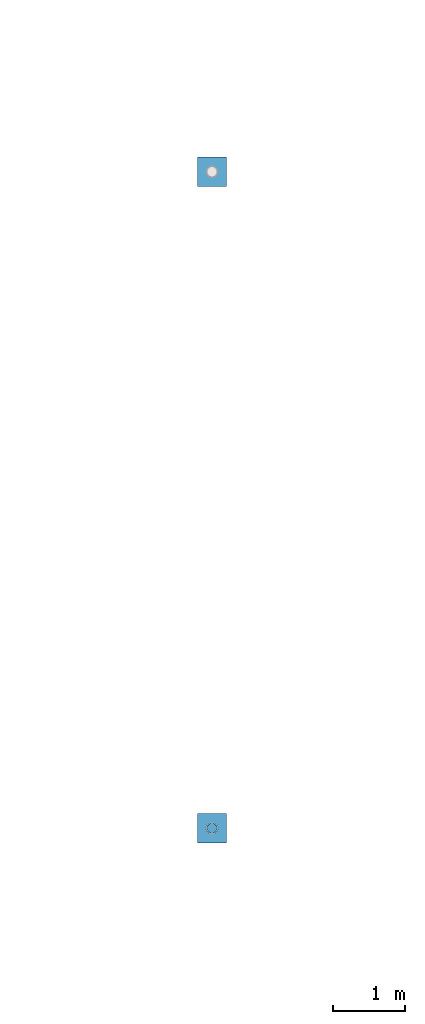
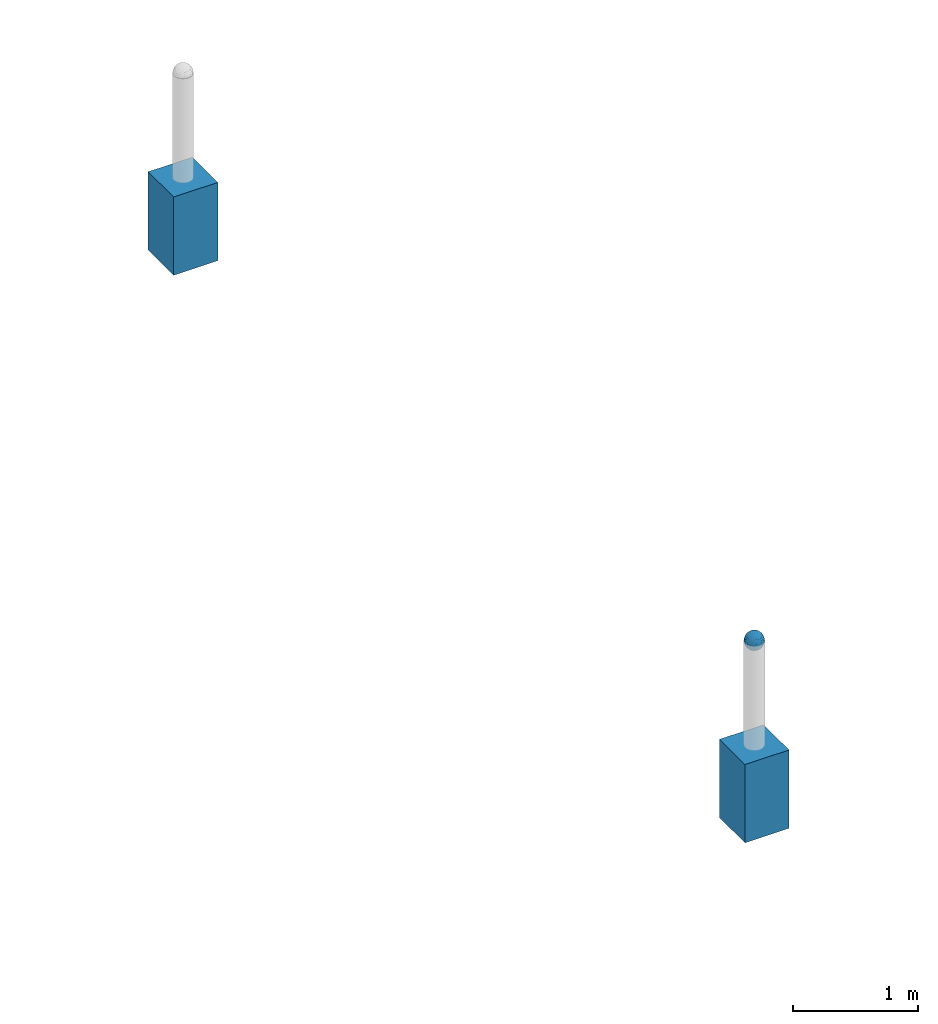
# One storey, part 1544 of 3843: 3 columns, 3 elements without a shape of their own.
"""IFC2X3 building model written with IfcOpenShell, lengths in millimetres."""

from ifc_helpers import new_model, si_unit, frame, origin_with_axes, place, context, subcontext, project, spatial, faceted_brep, material, type_object, element, aggregate, save


model = new_model("IFC2X3")

# Units and contexts
model_context = context("Model", 3, precision=1e-05, world=origin_with_axes())
body_context = subcontext(model_context, "Body", "Model", "MODEL_VIEW")
ifc_project = project(units=[si_unit("LENGTHUNIT", "METRE", prefix="MILLI"), si_unit("AREAUNIT", "SQUARE_METRE"), si_unit("VOLUMEUNIT", "CUBIC_METRE"), si_unit("MASSUNIT", "GRAM", prefix="KILO"), si_unit("TIMEUNIT", "SECOND"), si_unit("PLANEANGLEUNIT", "RADIAN"), si_unit("SOLIDANGLEUNIT", "STERADIAN"), si_unit("THERMODYNAMICTEMPERATUREUNIT", "DEGREE_CELSIUS"), si_unit("LUMINOUSINTENSITYUNIT", "LUMEN")], contexts=[model_context])

# Site, building, storey
site_placement = place(None, origin_with_axes())
site = spatial("IfcSite", under=ifc_project, at=site_placement, CompositionType="ELEMENT")
building_placement = place(site_placement, origin_with_axes())
building = spatial("IfcBuilding", under=site, at=building_placement, Name="Undefined", CompositionType="ELEMENT")
storey_placement = place(building_placement, origin_with_axes())
storey = spatial("IfcBuildingStorey", under=building, at=storey_placement, Name="Undefined", CompositionType="ELEMENT", Elevation=0.0)

# Assembly, column
assembly_1_placement = place(storey_placement, origin_with_axes())
assembly_1 = element("IfcElementAssembly", 1, at=assembly_1_placement, inside=storey, Name="CONC_COL.", AssemblyPlace="NOTDEFINED", PredefinedType="REINFORCEMENT_UNIT")
ifc_material_1 = material(Name="CONCRETE/3000")
column_type_1 = type_object("IfcColumnType", PredefinedType="NOTDEFINED")
column_1_placement = place(assembly_1_placement, frame((15156.5818631947, 73392.460174799, 29718.0), z_axis=(-1.0, 0.0, 0.0), x_axis=(0.0, 0.0, 1.0)))
column_1 = element("IfcColumn", 2, at=column_1_placement, type_object=column_type_1, material=ifc_material_1, Name="CONC_COL.", context=body_context, shape_type="Brep", body=[
    faceted_brep([(0.0, 203.199999999997, -203.200000000001), (0.0, 203.199999999997, 203.200000000001), (762.0, 203.199999999997, 203.200000000001), (762.0, 203.199999999997, -203.200000000001), (0.0, -203.199999999997, 203.200000000001), (762.0, -203.199999999997, 203.200000000001), (0.0, -203.199999999997, -203.200000000001), (762.0, -203.199999999997, -203.200000000001)], [[[0, 1, 2, 3]], [[1, 4, 5, 2]], [[4, 6, 7, 5]], [[6, 0, 3, 7]], [[5, 7, 3, 2]], [[6, 4, 1, 0]]]),
])
aggregate(assembly_1, [column_1])

assembly_2_placement = place(storey_placement, origin_with_axes())
assembly_2 = element("IfcElementAssembly", 3, at=assembly_2_placement, inside=storey, Name="CONC_COL.", AssemblyPlace="NOTDEFINED", PredefinedType="REINFORCEMENT_UNIT")
column_2_placement = place(assembly_2_placement, frame((15156.5570676625, 64276.8748476505, 29718.0), z_axis=(-1.0, 0.0, 0.0), x_axis=(0.0, 0.0, 1.0)))
column_2 = element("IfcColumn", 4, at=column_2_placement, type_object=column_type_1, material=ifc_material_1, Name="CONC_COL.", context=body_context, shape_type="Brep", body=[
    faceted_brep([(0.0, 203.199999999997, -203.200000000001), (0.0, 203.199999999997, 203.200000000001), (762.0, 203.199999999997, 203.200000000001), (762.0, 203.199999999997, -203.200000000001), (0.0, -203.199999999997, 203.200000000001), (762.0, -203.199999999997, 203.200000000001), (0.0, -203.199999999997, -203.200000000001), (762.0, -203.199999999997, -203.200000000001)], [[[0, 1, 2, 3]], [[1, 4, 5, 2]], [[4, 6, 7, 5]], [[6, 0, 3, 7]], [[5, 7, 3, 2]], [[6, 4, 1, 0]]]),
])
aggregate(assembly_2, [column_2])

assembly_3_placement = place(storey_placement, origin_with_axes())
assembly_3 = element("IfcElementAssembly", 5, at=assembly_3_placement, inside=storey, Name="CONC. FILL", AssemblyPlace="NOTDEFINED", PredefinedType="REINFORCEMENT_UNIT")
ifc_material_2 = material(Name="CONCRETE/1500")
column_type_2 = type_object("IfcColumnType", PredefinedType="NOTDEFINED")
column_3_placement = place(assembly_3_placement, frame((15156.5570676625, 64276.8748476505, 31411.8625), z_axis=(-1.0, 0.0, 0.0), x_axis=(0.0, 0.0, 1.0)))
column_3 = element("IfcColumn", 6, at=column_3_placement, type_object=column_type_2, material=ifc_material_2, Name="CONC. FILL", context=body_context, shape_type="Brep", body=[
    faceted_brep([(0.0, 0.0, 2.0), (0.0, -0.619999999995343, 1.89999999999964), (3.36549999999988, -7.1422259999963, 21.9814139999999), (3.36549999999988, 0.0, 23.1139999999996), (0.0, -1.17999999999302, 1.6200000000008), (3.36549999999988, -13.5910319999966, 18.6992260000006), (0.0, -1.61999999999534, 1.18000000000029), (3.36549999999988, -18.699225999997, 13.5910320000003), (0.0, -1.89999999999418, 0.6200000000008), (3.36549999999988, -21.9814139999944, 7.14222599999994), (0.0, -2.0, 0.0), (3.36549999999988, -23.1140000000014, 0.0), (0.0, -1.89999999999418, -0.6200000000008), (3.36549999999988, -21.9814139999944, -7.14222599999994), (0.0, -1.61999999999534, -1.18000000000029), (3.36549999999988, -18.699225999997, -13.5910320000003), (0.0, -1.17999999999302, -1.6200000000008), (3.36549999999988, -13.5910319999966, -18.6992260000006), (0.0, -0.619999999995343, -1.89999999999964), (3.36549999999988, -7.1422259999963, -21.9814139999999), (0.0, 0.0, -2.0), (3.36549999999988, 0.0, -23.1139999999996), (0.0, 0.619999999995343, -1.89999999999964), (3.36549999999988, 7.1422259999963, -21.9814139999999), (0.0, 1.17999999999302, -1.6200000000008), (3.36549999999988, 13.5910319999966, -18.6992260000006), (0.0, 1.61999999999534, -1.18000000000029), (3.36549999999988, 18.699225999997, -13.5910320000003), (0.0, 1.89999999999418, -0.6200000000008), (3.36549999999988, 21.9814139999944, -7.14222599999994), (0.0, 2.0, 0.0), (3.36549999999988, 23.1140000000014, 0.0), (0.0, 1.89999999999418, 0.6200000000008), (3.36549999999988, 21.9814139999944, 7.14222599999994), (0.0, 1.61999999999534, 1.18000000000029), (3.36549999999988, 18.699225999997, 13.5910320000003), (0.0, 1.17999999999302, 1.6200000000008), (3.36549999999988, 13.5910319999966, 18.6992260000006), (0.0, 0.619999999995343, 1.89999999999964), (3.36549999999988, 7.1422259999963, 21.9814139999999), (8.41374999999971, -11.1214661999984, 34.2282018000005), (8.41374999999971, 0.0, 35.9917999999998), (8.41374999999971, -21.1631784000056, 29.1173662000001), (8.41374999999971, -29.1173661999928, 21.1631784000001), (8.41374999999971, -34.2282017999969, 11.1214662000002), (8.41374999999971, -35.9918000000034, 0.0), (8.41374999999971, -34.2282017999969, -11.1214662000002), (8.41374999999971, -29.1173661999928, -21.1631784000001), (8.41374999999971, -21.1631784000056, -29.1173662000001), (8.41374999999971, -11.1214661999984, -34.2282018000005), (8.41374999999971, 0.0, -35.9917999999998), (8.41374999999971, 11.1214661999984, -34.2282018000005), (8.41374999999971, 21.1631784000056, -29.1173662000001), (8.41374999999971, 29.1173661999928, -21.1631784000001), (8.41374999999971, 34.2282017999969, -11.1214662000002), (8.41374999999971, 35.9918000000034, 0.0), (8.41374999999971, 34.2282017999969, 11.1214662000002), (8.41374999999971, 29.1173661999928, 21.1631784000001), (8.41374999999971, 21.1631784000056, 29.1173662000001), (8.41374999999971, 11.1214661999984, 34.2282018000005), (16.8274999999994, -15.3047700000025, 47.1030300000002), (16.8274999999994, 0.0, 49.5300000000007), (16.8274999999994, -29.1236400000053, 40.0697700000001), (16.8274999999994, -40.0697700000019, 29.1236399999998), (16.8274999999994, -47.1030299999984, 15.3047700000006), (16.8274999999994, -49.5299999999988, 0.0), (16.8274999999994, -47.1030299999984, -15.3047700000006), (16.8274999999994, -40.0697700000019, -29.1236399999998), (16.8274999999994, -29.1236400000053, -40.0697700000001), (16.8274999999994, -15.3047700000025, -47.1030300000002), (16.8274999999994, 0.0, -49.5300000000007), (16.8274999999994, 15.3047700000025, -47.1030300000002), (16.8274999999994, 29.1236400000053, -40.0697700000001), (16.8274999999994, 40.0697700000019, -29.1236399999998), (16.8274999999994, 47.1030299999984, -15.3047700000006), (16.8274999999994, 49.5299999999988, 0.0), (16.8274999999994, 47.1030299999984, 15.3047700000006), (16.8274999999994, 40.0697700000019, 29.1236399999998), (16.8274999999994, 29.1236400000053, 40.0697700000001), (16.8274999999994, 15.3047700000025, 47.1030300000002), (33.6549999999988, -20.4063599999936, 62.8040400000009), (33.6549999999988, 0.0, 66.0400000000009), (33.6549999999988, -38.831520000007, 53.4263599999995), (33.6549999999988, -53.4263599999977, 38.8315199999997), (33.6549999999988, -62.8040400000027, 20.4063600000009), (33.6549999999988, -66.0399999999936, 0.0), (33.6549999999988, -62.8040400000027, -20.4063600000009), (33.6549999999988, -53.4263599999977, -38.8315199999997), (33.6549999999988, -38.831520000007, -53.4263599999995), (33.6549999999988, -20.4063599999936, -62.8040400000009), (33.6549999999988, 0.0, -66.0400000000009), (33.6549999999988, 20.4063599999936, -62.8040400000009), (33.6549999999988, 38.831520000007, -53.4263599999995), (33.6549999999988, 53.4263599999977, -38.8315199999997), (33.6549999999988, 62.8040400000027, -20.4063600000009), (33.6549999999988, 66.0399999999936, 0.0), (33.6549999999988, 62.8040400000027, 20.4063600000009), (33.6549999999988, 53.4263599999977, 38.8315199999997), (33.6549999999988, 38.831520000007, 53.4263599999995), (33.6549999999988, 20.4063599999936, 62.8040400000009), (50.4824999999983, -23.3907901500061, 71.9891308499991), (50.4824999999983, 0.0, 75.6983500000006), (50.4824999999983, -44.5106298000028, 61.23996515), (50.4824999999983, -61.2399651500018, 44.5106297999992), (50.4824999999983, -71.9891308499937, 23.3907901500006), (50.4824999999983, -75.698350000006, 0.0), (50.4824999999983, -71.9891308499937, -23.3907901500006), (50.4824999999983, -61.2399651500018, -44.5106297999992), (50.4824999999983, -44.5106298000028, -61.23996515), (50.4824999999983, -23.3907901500061, -71.9891308499991), (50.4824999999983, 0.0, -75.6983500000006), (50.4824999999983, 23.3907901500061, -71.9891308499991), (50.4824999999983, 44.5106298000028, -61.23996515), (50.4824999999983, 61.2399651500018, -44.5106297999992), (50.4824999999983, 71.9891308499937, -23.3907901500006), (50.4824999999983, 75.698350000006, 0.0), (50.4824999999983, 71.9891308499937, 23.3907901500006), (50.4824999999983, 61.2399651500018, 44.5106297999992), (50.4824999999983, 44.5106298000028, 61.23996515), (50.4824999999983, 23.3907901500061, 71.9891308499991), (67.3099999999977, -24.9977910000016, 76.9349490000004), (67.3099999999977, 0.0, 80.8989999999994), (67.3099999999977, -47.5686120000028, 65.4472910000004), (67.3099999999977, -65.447291000004, 47.5686119999991), (67.3099999999977, -76.9349490000022, 24.9977909999998), (67.3099999999977, -80.8990000000049, 0.0), (67.3099999999977, -76.9349490000022, -24.9977909999998), (67.3099999999977, -65.447291000004, -47.5686119999991), (67.3099999999977, -47.5686120000028, -65.4472910000004), (67.3099999999977, -24.9977910000016, -76.9349490000004), (67.3099999999977, 0.0, -80.8989999999994), (67.3099999999977, 24.9977910000016, -76.9349490000004), (67.3099999999977, 47.5686120000028, -65.4472910000004), (67.3099999999977, 65.447291000004, -47.5686119999991), (67.3099999999977, 76.9349490000022, -24.9977909999998), (67.3099999999977, 80.8990000000049, 0.0), (67.3099999999977, 76.9349490000022, 24.9977909999998), (67.3099999999977, 65.447291000004, 47.5686119999991), (67.3099999999977, 47.5686120000028, 65.4472910000004), (67.3099999999977, 24.9977910000016, 76.9349490000004), (84.1374999999935, -25.5079499999993, 78.5050499999998), (84.1374999999935, 0.0, 82.5499999999993), (84.1374999999935, -48.5393999999942, 66.7829500000007), (84.1374999999935, -66.7829499999934, 48.5393999999997), (84.1374999999935, -78.505050000007, 25.5079499999993), (84.1374999999935, -82.5500000000029, 0.0), (84.1374999999935, -78.505050000007, -25.5079499999993), (84.1374999999935, -66.7829499999934, -48.5393999999997), (84.1374999999935, -48.5393999999942, -66.7829500000007), (84.1374999999935, -25.5079499999993, -78.5050499999998), (84.1374999999935, 0.0, -82.5499999999993), (84.1374999999935, 25.5079499999993, -78.5050499999998), (84.1374999999935, 48.5393999999942, -66.7829500000007), (84.1374999999935, 66.7829499999934, -48.5393999999997), (84.1374999999935, 78.505050000007, -25.5079499999993), (84.1374999999935, 82.5500000000029, 0.0), (84.1374999999935, 78.505050000007, 25.5079499999993), (84.1374999999935, 66.7829499999934, 48.5393999999997), (84.1374999999935, 48.5393999999942, 66.7829500000007), (84.1374999999935, 25.5079499999993, 78.5050499999998), (100.964999999993, -24.9977910000016, 76.9349490000004), (100.964999999993, 0.0, 80.8989999999994), (100.964999999993, -47.5686120000028, 65.4472910000004), (100.964999999993, -65.447291000004, 47.5686119999991), (100.964999999993, -76.9349490000022, 24.9977909999998), (100.964999999993, -80.8990000000049, 0.0), (100.964999999993, -76.9349490000022, -24.9977909999998), (100.964999999993, -65.447291000004, -47.5686119999991), (100.964999999993, -47.5686120000028, -65.4472910000004), (100.964999999993, -24.9977910000016, -76.9349490000004), (100.964999999993, 0.0, -80.8989999999994), (100.964999999993, 24.9977910000016, -76.9349490000004), (100.964999999993, 47.5686120000028, -65.4472910000004), (100.964999999993, 65.447291000004, -47.5686119999991), (100.964999999993, 76.9349490000022, -24.9977909999998), (100.964999999993, 80.8990000000049, 0.0), (100.964999999993, 76.9349490000022, 24.9977909999998), (100.964999999993, 65.447291000004, 47.5686119999991), (100.964999999993, 47.5686120000028, 65.4472910000004), (100.964999999993, 24.9977910000016, 76.9349490000004), (117.792499999992, -23.3907901500061, 71.9891308499991), (117.792499999992, 0.0, 75.6983500000006), (117.792499999992, -44.5106298000028, 61.23996515), (117.792499999992, -61.2399651500018, 44.5106297999992), (117.792499999992, -71.9891308499937, 23.3907901500006), (117.792499999992, -75.698350000006, 0.0), (117.792499999992, -71.9891308499937, -23.3907901500006), (117.792499999992, -61.2399651500018, -44.5106297999992), (117.792499999992, -44.5106298000028, -61.23996515), (117.792499999992, -23.3907901500061, -71.9891308499991), (117.792499999992, 0.0, -75.6983500000006), (117.792499999992, 23.3907901500061, -71.9891308499991), (117.792499999992, 44.5106298000028, -61.23996515), (117.792499999992, 61.2399651500018, -44.5106297999992), (117.792499999992, 71.9891308499937, -23.3907901500006), (117.792499999992, 75.698350000006, 0.0), (117.792499999992, 71.9891308499937, 23.3907901500006), (117.792499999992, 61.2399651500018, 44.5106297999992), (117.792499999992, 44.5106298000028, 61.23996515), (117.792499999992, 23.3907901500061, 71.9891308499991), (134.619999999992, -20.4063599999936, 62.8040400000009), (134.619999999992, 0.0, 66.0400000000009), (134.619999999992, -38.831520000007, 53.4263599999995), (134.619999999992, -53.4263599999977, 38.8315199999997), (134.619999999992, -62.8040400000027, 20.4063600000009), (134.619999999992, -66.0399999999936, 0.0), (134.619999999992, -62.8040400000027, -20.4063600000009), (134.619999999992, -53.4263599999977, -38.8315199999997), (134.619999999992, -38.831520000007, -53.4263599999995), (134.619999999992, -20.4063599999936, -62.8040400000009), (134.619999999992, 0.0, -66.0400000000009), (134.619999999992, 20.4063599999936, -62.8040400000009), (134.619999999992, 38.831520000007, -53.4263599999995), (134.619999999992, 53.4263599999977, -38.8315199999997), (134.619999999992, 62.8040400000027, -20.4063600000009), (134.619999999992, 66.0399999999936, 0.0), (134.619999999992, 62.8040400000027, 20.4063600000009), (134.619999999992, 53.4263599999977, 38.8315199999997), (134.619999999992, 38.831520000007, 53.4263599999995), (134.619999999992, 20.4063599999936, 62.8040400000009), (151.447499999991, -15.3047700000025, 47.1030300000002), (151.447499999991, 0.0, 49.5300000000007), (151.447499999991, -29.1236400000053, 40.0697700000001), (151.447499999991, -40.0697700000019, 29.1236399999998), (151.447499999991, -47.1030299999984, 15.3047700000006), (151.447499999991, -49.5299999999988, 0.0), (151.447499999991, -47.1030299999984, -15.3047700000006), (151.447499999991, -40.0697700000019, -29.1236399999998), (151.447499999991, -29.1236400000053, -40.0697700000001), (151.447499999991, -15.3047700000025, -47.1030300000002), (151.447499999991, 0.0, -49.5300000000007), (151.447499999991, 15.3047700000025, -47.1030300000002), (151.447499999991, 29.1236400000053, -40.0697700000001), (151.447499999991, 40.0697700000019, -29.1236399999998), (151.447499999991, 47.1030299999984, -15.3047700000006), (151.447499999991, 49.5299999999988, 0.0), (151.447499999991, 47.1030299999984, 15.3047700000006), (151.447499999991, 40.0697700000019, 29.1236399999998), (151.447499999991, 29.1236400000053, 40.0697700000001), (151.447499999991, 15.3047700000025, 47.1030300000002), (159.861249999991, -11.1214661999984, 34.2282018000005), (159.861249999991, 0.0, 35.9917999999998), (159.861249999991, -21.1631784000056, 29.1173662000001), (159.861249999991, -29.1173661999928, 21.1631784000001), (159.861249999991, -34.2282017999969, 11.1214662000002), (159.861249999991, -35.9918000000034, 0.0), (159.861249999991, -34.2282017999969, -11.1214662000002), (159.861249999991, -29.1173661999928, -21.1631784000001), (159.861249999991, -21.1631784000056, -29.1173662000001), (159.861249999991, -11.1214661999984, -34.2282018000005), (159.861249999991, 0.0, -35.9917999999998), (159.861249999991, 11.1214661999984, -34.2282018000005), (159.861249999991, 21.1631784000056, -29.1173662000001), (159.861249999991, 29.1173661999928, -21.1631784000001), (159.861249999991, 34.2282017999969, -11.1214662000002), (159.861249999991, 35.9918000000034, 0.0), (159.861249999991, 34.2282017999969, 11.1214662000002), (159.861249999991, 29.1173661999928, 21.1631784000001), (159.861249999991, 21.1631784000056, 29.1173662000001), (159.861249999991, 11.1214661999984, 34.2282018000005), (164.909499999991, -7.1422259999963, 21.9814139999999), (164.909499999991, 0.0, 23.1139999999996), (164.909499999991, -13.5910319999966, 18.6992260000006), (164.909499999991, -18.699225999997, 13.5910320000003), (164.909499999991, -21.9814139999944, 7.14222599999994), (164.909499999991, -23.1140000000014, 0.0), (164.909499999991, -21.9814139999944, -7.14222599999994), (164.909499999991, -18.699225999997, -13.5910320000003), (164.909499999991, -13.5910319999966, -18.6992260000006), (164.909499999991, -7.1422259999963, -21.9814139999999), (164.909499999991, 0.0, -23.1139999999996), (164.909499999991, 7.1422259999963, -21.9814139999999), (164.909499999991, 13.5910319999966, -18.6992260000006), (164.909499999991, 18.699225999997, -13.5910320000003), (164.909499999991, 21.9814139999944, -7.14222599999994), (164.909499999991, 23.1140000000014, 0.0), (164.909499999991, 21.9814139999944, 7.14222599999994), (164.909499999991, 18.699225999997, 13.5910320000003), (164.909499999991, 13.5910319999966, 18.6992260000006), (164.909499999991, 7.1422259999963, 21.9814139999999), (168.274999999991, -0.619999999995343, 1.89999999999964), (168.274999999991, 0.0, 2.0), (168.274999999991, -1.17999999999302, 1.6200000000008), (168.274999999991, -1.61999999999534, 1.18000000000029), (168.274999999991, -1.89999999999418, 0.6200000000008), (168.274999999991, -2.0, 0.0), (168.274999999991, -1.89999999999418, -0.6200000000008), (168.274999999991, -1.61999999999534, -1.18000000000029), (168.274999999991, -1.17999999999302, -1.6200000000008), (168.274999999991, -0.619999999995343, -1.89999999999964), (168.274999999991, 0.0, -2.0), (168.274999999991, 0.619999999995343, -1.89999999999964), (168.274999999991, 1.17999999999302, -1.6200000000008), (168.274999999991, 1.61999999999534, -1.18000000000029), (168.274999999991, 1.89999999999418, -0.6200000000008), (168.274999999991, 2.0, 0.0), (168.274999999991, 1.89999999999418, 0.6200000000008), (168.274999999991, 1.61999999999534, 1.18000000000029), (168.274999999991, 1.17999999999302, 1.6200000000008), (168.274999999991, 0.619999999995343, 1.89999999999964)], [[[0, 1, 2, 3]], [[1, 4, 5, 2]], [[4, 6, 7, 5]], [[6, 8, 9, 7]], [[8, 10, 11, 9]], [[10, 12, 13, 11]], [[12, 14, 15, 13]], [[14, 16, 17, 15]], [[16, 18, 19, 17]], [[18, 20, 21, 19]], [[20, 22, 23, 21]], [[22, 24, 25, 23]], [[24, 26, 27, 25]], [[26, 28, 29, 27]], [[28, 30, 31, 29]], [[30, 32, 33, 31]], [[32, 34, 35, 33]], [[34, 36, 37, 35]], [[36, 38, 39, 37]], [[38, 0, 3, 39]], [[38, 36, 34, 32, 30, 28, 26, 24, 22, 20, 18, 16, 14, 12, 10, 8, 6, 4, 1, 0]], [[3, 2, 40, 41]], [[2, 5, 42, 40]], [[5, 7, 43, 42]], [[7, 9, 44, 43]], [[9, 11, 45, 44]], [[11, 13, 46, 45]], [[13, 15, 47, 46]], [[15, 17, 48, 47]], [[17, 19, 49, 48]], [[19, 21, 50, 49]], [[21, 23, 51, 50]], [[23, 25, 52, 51]], [[25, 27, 53, 52]], [[27, 29, 54, 53]], [[29, 31, 55, 54]], [[31, 33, 56, 55]], [[33, 35, 57, 56]], [[35, 37, 58, 57]], [[37, 39, 59, 58]], [[39, 3, 41, 59]], [[41, 40, 60, 61]], [[40, 42, 62, 60]], [[42, 43, 63, 62]], [[43, 44, 64, 63]], [[44, 45, 65, 64]], [[45, 46, 66, 65]], [[46, 47, 67, 66]], [[47, 48, 68, 67]], [[48, 49, 69, 68]], [[49, 50, 70, 69]], [[50, 51, 71, 70]], [[51, 52, 72, 71]], [[52, 53, 73, 72]], [[53, 54, 74, 73]], [[54, 55, 75, 74]], [[55, 56, 76, 75]], [[56, 57, 77, 76]], [[57, 58, 78, 77]], [[58, 59, 79, 78]], [[59, 41, 61, 79]], [[61, 60, 80, 81]], [[60, 62, 82, 80]], [[62, 63, 83, 82]], [[63, 64, 84, 83]], [[64, 65, 85, 84]], [[65, 66, 86, 85]], [[66, 67, 87, 86]], [[67, 68, 88, 87]], [[68, 69, 89, 88]], [[69, 70, 90, 89]], [[70, 71, 91, 90]], [[71, 72, 92, 91]], [[72, 73, 93, 92]], [[73, 74, 94, 93]], [[74, 75, 95, 94]], [[75, 76, 96, 95]], [[76, 77, 97, 96]], [[77, 78, 98, 97]], [[78, 79, 99, 98]], [[79, 61, 81, 99]], [[81, 80, 100, 101]], [[80, 82, 102, 100]], [[82, 83, 103, 102]], [[83, 84, 104, 103]], [[84, 85, 105, 104]], [[85, 86, 106, 105]], [[86, 87, 107, 106]], [[87, 88, 108, 107]], [[88, 89, 109, 108]], [[89, 90, 110, 109]], [[90, 91, 111, 110]], [[91, 92, 112, 111]], [[92, 93, 113, 112]], [[93, 94, 114, 113]], [[94, 95, 115, 114]], [[95, 96, 116, 115]], [[96, 97, 117, 116]], [[97, 98, 118, 117]], [[98, 99, 119, 118]], [[99, 81, 101, 119]], [[101, 100, 120, 121]], [[100, 102, 122, 120]], [[102, 103, 123, 122]], [[103, 104, 124, 123]], [[104, 105, 125, 124]], [[105, 106, 126, 125]], [[106, 107, 127, 126]], [[107, 108, 128, 127]], [[108, 109, 129, 128]], [[109, 110, 130, 129]], [[110, 111, 131, 130]], [[111, 112, 132, 131]], [[112, 113, 133, 132]], [[113, 114, 134, 133]], [[114, 115, 135, 134]], [[115, 116, 136, 135]], [[116, 117, 137, 136]], [[117, 118, 138, 137]], [[118, 119, 139, 138]], [[119, 101, 121, 139]], [[121, 120, 140, 141]], [[120, 122, 142, 140]], [[122, 123, 143, 142]], [[123, 124, 144, 143]], [[124, 125, 145, 144]], [[125, 126, 146, 145]], [[126, 127, 147, 146]], [[127, 128, 148, 147]], [[128, 129, 149, 148]], [[129, 130, 150, 149]], [[130, 131, 151, 150]], [[131, 132, 152, 151]], [[132, 133, 153, 152]], [[133, 134, 154, 153]], [[134, 135, 155, 154]], [[135, 136, 156, 155]], [[136, 137, 157, 156]], [[137, 138, 158, 157]], [[138, 139, 159, 158]], [[139, 121, 141, 159]], [[141, 140, 160, 161]], [[140, 142, 162, 160]], [[142, 143, 163, 162]], [[143, 144, 164, 163]], [[144, 145, 165, 164]], [[145, 146, 166, 165]], [[146, 147, 167, 166]], [[147, 148, 168, 167]], [[148, 149, 169, 168]], [[149, 150, 170, 169]], [[150, 151, 171, 170]], [[151, 152, 172, 171]], [[152, 153, 173, 172]], [[153, 154, 174, 173]], [[154, 155, 175, 174]], [[155, 156, 176, 175]], [[156, 157, 177, 176]], [[157, 158, 178, 177]], [[158, 159, 179, 178]], [[159, 141, 161, 179]], [[161, 160, 180, 181]], [[160, 162, 182, 180]], [[162, 163, 183, 182]], [[163, 164, 184, 183]], [[164, 165, 185, 184]], [[165, 166, 186, 185]], [[166, 167, 187, 186]], [[167, 168, 188, 187]], [[168, 169, 189, 188]], [[169, 170, 190, 189]], [[170, 171, 191, 190]], [[171, 172, 192, 191]], [[172, 173, 193, 192]], [[173, 174, 194, 193]], [[174, 175, 195, 194]], [[175, 176, 196, 195]], [[176, 177, 197, 196]], [[177, 178, 198, 197]], [[178, 179, 199, 198]], [[179, 161, 181, 199]], [[181, 180, 200, 201]], [[180, 182, 202, 200]], [[182, 183, 203, 202]], [[183, 184, 204, 203]], [[184, 185, 205, 204]], [[185, 186, 206, 205]], [[186, 187, 207, 206]], [[187, 188, 208, 207]], [[188, 189, 209, 208]], [[189, 190, 210, 209]], [[190, 191, 211, 210]], [[191, 192, 212, 211]], [[192, 193, 213, 212]], [[193, 194, 214, 213]], [[194, 195, 215, 214]], [[195, 196, 216, 215]], [[196, 197, 217, 216]], [[197, 198, 218, 217]], [[198, 199, 219, 218]], [[199, 181, 201, 219]], [[201, 200, 220, 221]], [[200, 202, 222, 220]], [[202, 203, 223, 222]], [[203, 204, 224, 223]], [[204, 205, 225, 224]], [[205, 206, 226, 225]], [[206, 207, 227, 226]], [[207, 208, 228, 227]], [[208, 209, 229, 228]], [[209, 210, 230, 229]], [[210, 211, 231, 230]], [[211, 212, 232, 231]], [[212, 213, 233, 232]], [[213, 214, 234, 233]], [[214, 215, 235, 234]], [[215, 216, 236, 235]], [[216, 217, 237, 236]], [[217, 218, 238, 237]], [[218, 219, 239, 238]], [[219, 201, 221, 239]], [[221, 220, 240, 241]], [[220, 222, 242, 240]], [[222, 223, 243, 242]], [[223, 224, 244, 243]], [[224, 225, 245, 244]], [[225, 226, 246, 245]], [[226, 227, 247, 246]], [[227, 228, 248, 247]], [[228, 229, 249, 248]], [[229, 230, 250, 249]], [[230, 231, 251, 250]], [[231, 232, 252, 251]], [[232, 233, 253, 252]], [[233, 234, 254, 253]], [[234, 235, 255, 254]], [[235, 236, 256, 255]], [[236, 237, 257, 256]], [[237, 238, 258, 257]], [[238, 239, 259, 258]], [[239, 221, 241, 259]], [[241, 240, 260, 261]], [[240, 242, 262, 260]], [[242, 243, 263, 262]], [[243, 244, 264, 263]], [[244, 245, 265, 264]], [[245, 246, 266, 265]], [[246, 247, 267, 266]], [[247, 248, 268, 267]], [[248, 249, 269, 268]], [[249, 250, 270, 269]], [[250, 251, 271, 270]], [[251, 252, 272, 271]], [[252, 253, 273, 272]], [[253, 254, 274, 273]], [[254, 255, 275, 274]], [[255, 256, 276, 275]], [[256, 257, 277, 276]], [[257, 258, 278, 277]], [[258, 259, 279, 278]], [[259, 241, 261, 279]], [[261, 260, 280, 281]], [[260, 262, 282, 280]], [[262, 263, 283, 282]], [[263, 264, 284, 283]], [[264, 265, 285, 284]], [[265, 266, 286, 285]], [[266, 267, 287, 286]], [[267, 268, 288, 287]], [[268, 269, 289, 288]], [[269, 270, 290, 289]], [[270, 271, 291, 290]], [[271, 272, 292, 291]], [[272, 273, 293, 292]], [[273, 274, 294, 293]], [[274, 275, 295, 294]], [[275, 276, 296, 295]], [[276, 277, 297, 296]], [[277, 278, 298, 297]], [[278, 279, 299, 298]], [[279, 261, 281, 299]], [[282, 283, 284, 285, 286, 287, 288, 289, 290, 291, 292, 293, 294, 295, 296, 297, 298, 299, 281, 280]]]),
])
aggregate(assembly_3, [column_3])

save(model, "model.ifc")
